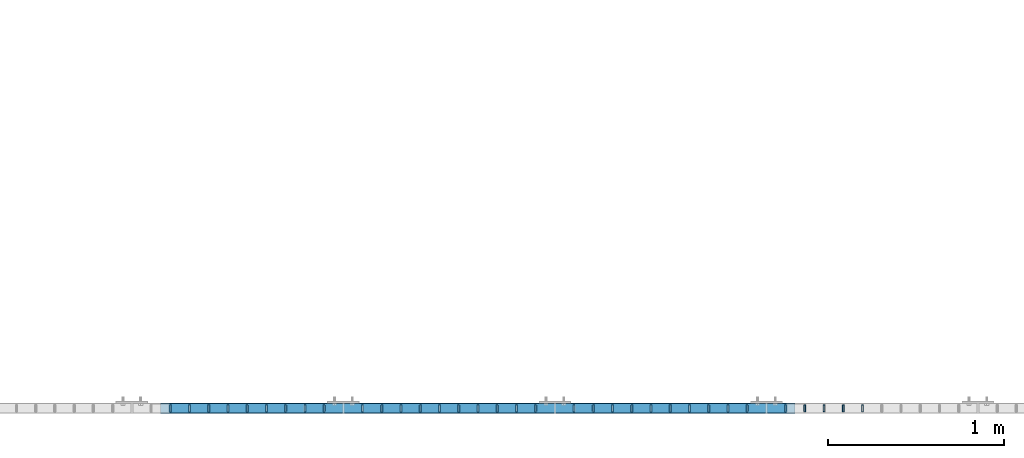
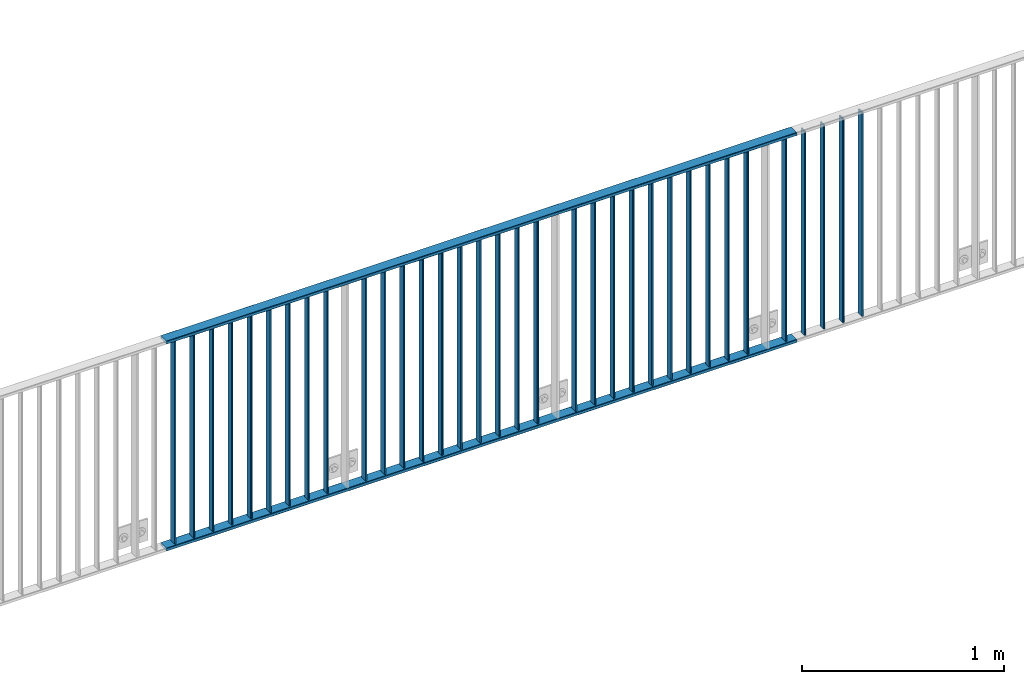
# One storey, part 30 of 156: 36 beams, 2 elements without a shape of their own.
"""IFC2X3 building model written with IfcOpenShell, lengths in millimetres."""

from ifc_helpers import new_model, si_unit, frame, origin_with_axes, origin_2d_with_axis, place, context, subcontext, project, spatial, hollow_rectangle, extrude, clip, halfspace, material, type_object, element, aggregate, save


model = new_model("IFC2X3")

# Units and contexts
model_context = context("Model", 3, precision=1e-05, world=origin_with_axes())
body_context = subcontext(model_context, "Body", "Model", "MODEL_VIEW")
ifc_project = project(units=[si_unit("LENGTHUNIT", "METRE", prefix="MILLI"), si_unit("AREAUNIT", "SQUARE_METRE"), si_unit("VOLUMEUNIT", "CUBIC_METRE"), si_unit("MASSUNIT", "GRAM", prefix="KILO"), si_unit("TIMEUNIT", "SECOND"), si_unit("PLANEANGLEUNIT", "RADIAN"), si_unit("SOLIDANGLEUNIT", "STERADIAN"), si_unit("THERMODYNAMICTEMPERATUREUNIT", "DEGREE_CELSIUS"), si_unit("LUMINOUSINTENSITYUNIT", "LUMEN")], contexts=[model_context])

# Site, building, storey
site_placement = place(None, origin_with_axes())
site = spatial("IfcSite", under=ifc_project, at=site_placement, CompositionType="ELEMENT")
building_placement = place(site_placement, origin_with_axes())
building = spatial("IfcBuilding", under=site, at=building_placement, Name="Undefined", CompositionType="ELEMENT")
storey_placement = place(building_placement, origin_with_axes())
storey = spatial("IfcBuildingStorey", under=building, at=storey_placement, Name="Undefined", CompositionType="ELEMENT", Elevation=0.0)

# Assembly, beams
assembly_1_placement = place(storey_placement, origin_with_axes())
assembly_1 = element("IfcElementAssembly", 1, at=assembly_1_placement, inside=storey, AssemblyPlace="NOTDEFINED", PredefinedType="RIGID_FRAME")
ifc_material = material(Name="STEEL/S235JR")
beam_type_1 = type_object("IfcBeamType", Name="K60/20/2", PredefinedType="NOTDEFINED")
beam_1_placement = place(assembly_1_placement, frame((43163.039999999, 8480.00209045411, 2740.0), z_axis=(0.0, 1.0, 0.0), x_axis=(1.0, 0.0, 0.0)))
beam_1 = element("IfcBeam", 2, at=beam_1_placement, type_object=beam_type_1, material=ifc_material, ObjectType="K60/20/2", context=body_context, shape_type="SweptSolid", body=[
    extrude(hollow_rectangle(XDim=20.0, YDim=60.0, WallThickness=2.0, InnerFilletRadius=2.0, OuterFilletRadius=4.0, at=origin_2d_with_axis()), frame((3600.0, 0.0, 0.0), z_axis=(-1.0, 0.0, 0.0), x_axis=(0.0, -1.0, 0.0)), (0.0, 0.0, 1.0), 3600.0),
])
beam_2_placement = place(assembly_1_placement, frame((43163.0400000136, 8479.98209040439, 3990.0), z_axis=(0.0, 1.0, 0.0), x_axis=(1.0, 0.0, 0.0)))
beam_2 = element("IfcBeam", 3, at=beam_2_placement, type_object=beam_type_1, material=ifc_material, ObjectType="K60/20/2", context=body_context, shape_type="SweptSolid", body=[
    extrude(hollow_rectangle(XDim=20.0, YDim=60.0, WallThickness=2.0, InnerFilletRadius=2.0, OuterFilletRadius=4.0, at=origin_2d_with_axis()), frame((3600.0, 0.0, 0.0), z_axis=(-1.0, 0.0, 0.0), x_axis=(0.0, -1.0, 0.0)), (0.0, 0.0, 1.0), 3600.0),
])

assembly_2_placement = place(storey_placement, origin_with_axes())
assembly_2 = element("IfcElementAssembly", 4, at=assembly_2_placement, inside=storey, AssemblyPlace="NOTDEFINED", PredefinedType="RIGID_FRAME")
beam_type_2 = type_object("IfcBeamType", Name="K40/10/1.5", PredefinedType="NOTDEFINED")
beam_3_placement = place(assembly_2_placement, frame((47145.449999999, 8480.00209765299, 3980.00000000003), z_axis=(0.0, 1.0, 0.0), x_axis=(0.0, 0.0, -1.0)))
beam_3 = element("IfcBeam", 5, at=beam_3_placement, type_object=beam_type_2, material=ifc_material, ObjectType="K40/10/1.5", context=body_context, shape_type="Clipping", body=[
    clip(extrude(hollow_rectangle(XDim=10.0, YDim=40.0, WallThickness=1.5, InnerFilletRadius=1.5, OuterFilletRadius=3.0, at=origin_2d_with_axis()), frame((1230.0, 0.0, 0.0), z_axis=(-1.0, 0.0, 0.0), x_axis=(0.0, -1.0, 0.0)), (0.0, 0.0, 1.0), 1230.0), halfspace(frame((-6.99999999997453, -4.34248751950508, 47.3810900558092), z_axis=(-1.0, 0.0, 0.0), x_axis=(0.0, 0.7683548141934, -0.640024124159258)), False)),
])
beam_4_placement = place(assembly_2_placement, frame((47036.359999999, 8480.00209765299, 3980.00000000003), z_axis=(0.0, 1.0, 0.0), x_axis=(0.0, 0.0, -1.0)))
beam_4 = element("IfcBeam", 6, at=beam_4_placement, type_object=beam_type_2, material=ifc_material, ObjectType="K40/10/1.5", context=body_context, shape_type="Clipping", body=[
    clip(extrude(hollow_rectangle(XDim=10.0, YDim=40.0, WallThickness=1.5, InnerFilletRadius=1.5, OuterFilletRadius=3.0, at=origin_2d_with_axis()), frame((1230.0, 0.0, 0.0), z_axis=(-1.0, 0.0, 0.0), x_axis=(0.0, -1.0, 0.0)), (0.0, 0.0, 1.0), 1230.0), halfspace(frame((-6.99999999997453, -4.34248751950508, 47.3810900558092), z_axis=(-1.0, 0.0, 0.0), x_axis=(0.0, 0.7683548141934, -0.640024124159258)), False)),
])
beam_5_placement = place(assembly_2_placement, frame((46927.269999999, 8480.00209765299, 3980.00000000003), z_axis=(0.0, 1.0, 0.0), x_axis=(0.0, 0.0, -1.0)))
beam_5 = element("IfcBeam", 7, at=beam_5_placement, type_object=beam_type_2, material=ifc_material, ObjectType="K40/10/1.5", context=body_context, shape_type="Clipping", body=[
    clip(extrude(hollow_rectangle(XDim=10.0, YDim=40.0, WallThickness=1.5, InnerFilletRadius=1.5, OuterFilletRadius=3.0, at=origin_2d_with_axis()), frame((1230.0, 0.0, 0.0), z_axis=(-1.0, 0.0, 0.0), x_axis=(0.0, -1.0, 0.0)), (0.0, 0.0, 1.0), 1230.0), halfspace(frame((-6.99999999997453, -4.34248751950508, 47.3810900558092), z_axis=(-1.0, 0.0, 0.0), x_axis=(0.0, 0.7683548141934, -0.640024124159258)), False)),
])
beam_6_placement = place(assembly_2_placement, frame((46818.179999999, 8480.00209765299, 3980.00000000003), z_axis=(0.0, 1.0, 0.0), x_axis=(0.0, 0.0, -1.0)))
beam_6 = element("IfcBeam", 8, at=beam_6_placement, type_object=beam_type_2, material=ifc_material, ObjectType="K40/10/1.5", context=body_context, shape_type="Clipping", body=[
    clip(extrude(hollow_rectangle(XDim=10.0, YDim=40.0, WallThickness=1.5, InnerFilletRadius=1.5, OuterFilletRadius=3.0, at=origin_2d_with_axis()), frame((1230.0, 0.0, 0.0), z_axis=(-1.0, 0.0, 0.0), x_axis=(0.0, -1.0, 0.0)), (0.0, 0.0, 1.0), 1230.0), halfspace(frame((-6.99999999997453, -4.34248751950508, 47.3810900558092), z_axis=(-1.0, 0.0, 0.0), x_axis=(0.0, 0.7683548141934, -0.640024124159258)), False)),
])
aggregate(assembly_2, [beam_3, beam_4, beam_5, beam_6])

# Beam
beam_7_placement = place(assembly_1_placement, frame((46709.089999999, 8480.00209765299, 3980.00000000003), z_axis=(0.0, 1.0, 0.0), x_axis=(0.0, 0.0, -1.0)))
beam_7 = element("IfcBeam", 9, at=beam_7_placement, type_object=beam_type_2, material=ifc_material, ObjectType="K40/10/1.5", context=body_context, shape_type="Clipping", body=[
    clip(clip(extrude(hollow_rectangle(XDim=10.0, YDim=40.0, WallThickness=1.5, InnerFilletRadius=1.5, OuterFilletRadius=3.0, at=origin_2d_with_axis()), frame((1230.0, 0.0, 0.0), z_axis=(-1.0, 0.0, 0.0), x_axis=(0.0, -1.0, 0.0)), (0.0, 0.0, 1.0), 1237.0), halfspace(frame((1237.00000000003, 4.34248751949781, 47.3810900558092), z_axis=(1.0, 0.0, 0.0), x_axis=(0.0, -0.768354814194188, -0.640024124158313)), False)), halfspace(frame((-6.99999999997408, 56.3749450528248, -3.21677038838243), z_axis=(-1.0, 0.0, 0.0), x_axis=(0.0, 0.0578016019523036, -0.998328089763955)), False)),
])

beam_8_placement = place(assembly_1_placement, frame((46490.899999999, 8480.00209765299, 3980.00000000003), z_axis=(0.0, 1.0, 0.0), x_axis=(0.0, 0.0, -1.0)))
beam_8 = element("IfcBeam", 10, at=beam_8_placement, type_object=beam_type_2, material=ifc_material, ObjectType="K40/10/1.5", context=body_context, shape_type="Clipping", body=[
    clip(extrude(hollow_rectangle(XDim=10.0, YDim=40.0, WallThickness=1.5, InnerFilletRadius=1.5, OuterFilletRadius=3.0, at=origin_2d_with_axis()), frame((1230.0, 0.0, 0.0), z_axis=(-1.0, 0.0, 0.0), x_axis=(0.0, -1.0, 0.0)), (0.0, 0.0, 1.0), 1230.0), halfspace(frame((-6.99999999997453, -4.34248751950508, 47.3810900558092), z_axis=(-1.0, 0.0, 0.0), x_axis=(0.0, 0.7683548141934, -0.640024124159258)), False)),
])

beam_9_placement = place(assembly_1_placement, frame((46381.809999999, 8480.00209765299, 3980.00000000003), z_axis=(0.0, 1.0, 0.0), x_axis=(0.0, 0.0, -1.0)))
beam_9 = element("IfcBeam", 11, at=beam_9_placement, type_object=beam_type_2, material=ifc_material, ObjectType="K40/10/1.5", context=body_context, shape_type="Clipping", body=[
    clip(extrude(hollow_rectangle(XDim=10.0, YDim=40.0, WallThickness=1.5, InnerFilletRadius=1.5, OuterFilletRadius=3.0, at=origin_2d_with_axis()), frame((1230.0, 0.0, 0.0), z_axis=(-1.0, 0.0, 0.0), x_axis=(0.0, -1.0, 0.0)), (0.0, 0.0, 1.0), 1230.0), halfspace(frame((-6.99999999997453, -4.34248751950508, 47.3810900558092), z_axis=(-1.0, 0.0, 0.0), x_axis=(0.0, 0.7683548141934, -0.640024124159258)), False)),
])

beam_10_placement = place(assembly_1_placement, frame((46272.719999999, 8480.00209765299, 3980.00000000003), z_axis=(0.0, 1.0, 0.0), x_axis=(0.0, 0.0, -1.0)))
beam_10 = element("IfcBeam", 12, at=beam_10_placement, type_object=beam_type_2, material=ifc_material, ObjectType="K40/10/1.5", context=body_context, shape_type="Clipping", body=[
    clip(extrude(hollow_rectangle(XDim=10.0, YDim=40.0, WallThickness=1.5, InnerFilletRadius=1.5, OuterFilletRadius=3.0, at=origin_2d_with_axis()), frame((1230.0, 0.0, 0.0), z_axis=(-1.0, 0.0, 0.0), x_axis=(0.0, -1.0, 0.0)), (0.0, 0.0, 1.0), 1230.0), halfspace(frame((-6.99999999997453, -4.34248751950508, 47.3810900558092), z_axis=(-1.0, 0.0, 0.0), x_axis=(0.0, 0.7683548141934, -0.640024124159258)), False)),
])

beam_11_placement = place(assembly_1_placement, frame((46163.629999999, 8480.00209765299, 3980.00000000003), z_axis=(0.0, 1.0, 0.0), x_axis=(0.0, 0.0, -1.0)))
beam_11 = element("IfcBeam", 13, at=beam_11_placement, type_object=beam_type_2, material=ifc_material, ObjectType="K40/10/1.5", context=body_context, shape_type="Clipping", body=[
    clip(extrude(hollow_rectangle(XDim=10.0, YDim=40.0, WallThickness=1.5, InnerFilletRadius=1.5, OuterFilletRadius=3.0, at=origin_2d_with_axis()), frame((1230.0, 0.0, 0.0), z_axis=(-1.0, 0.0, 0.0), x_axis=(0.0, -1.0, 0.0)), (0.0, 0.0, 1.0), 1230.0), halfspace(frame((-6.99999999997453, -4.34248751950508, 47.3810900558092), z_axis=(-1.0, 0.0, 0.0), x_axis=(0.0, 0.7683548141934, -0.640024124159258)), False)),
])

beam_12_placement = place(assembly_1_placement, frame((46054.539999999, 8480.00209765299, 3980.00000000003), z_axis=(0.0, 1.0, 0.0), x_axis=(0.0, 0.0, -1.0)))
beam_12 = element("IfcBeam", 14, at=beam_12_placement, type_object=beam_type_2, material=ifc_material, ObjectType="K40/10/1.5", context=body_context, shape_type="Clipping", body=[
    clip(extrude(hollow_rectangle(XDim=10.0, YDim=40.0, WallThickness=1.5, InnerFilletRadius=1.5, OuterFilletRadius=3.0, at=origin_2d_with_axis()), frame((1230.0, 0.0, 0.0), z_axis=(-1.0, 0.0, 0.0), x_axis=(0.0, -1.0, 0.0)), (0.0, 0.0, 1.0), 1230.0), halfspace(frame((-6.99999999997453, -4.34248751950508, 47.3810900558092), z_axis=(-1.0, 0.0, 0.0), x_axis=(0.0, 0.7683548141934, -0.640024124159258)), False)),
])

beam_13_placement = place(assembly_1_placement, frame((45945.449999999, 8480.00209765299, 3980.00000000003), z_axis=(0.0, 1.0, 0.0), x_axis=(0.0, 0.0, -1.0)))
beam_13 = element("IfcBeam", 15, at=beam_13_placement, type_object=beam_type_2, material=ifc_material, ObjectType="K40/10/1.5", context=body_context, shape_type="Clipping", body=[
    clip(extrude(hollow_rectangle(XDim=10.0, YDim=40.0, WallThickness=1.5, InnerFilletRadius=1.5, OuterFilletRadius=3.0, at=origin_2d_with_axis()), frame((1230.0, 0.0, 0.0), z_axis=(-1.0, 0.0, 0.0), x_axis=(0.0, -1.0, 0.0)), (0.0, 0.0, 1.0), 1230.0), halfspace(frame((-6.99999999997453, -4.34248751950508, 47.3810900558092), z_axis=(-1.0, 0.0, 0.0), x_axis=(0.0, 0.7683548141934, -0.640024124159258)), False)),
])

beam_14_placement = place(assembly_1_placement, frame((45836.359999999, 8480.00209765299, 3980.00000000003), z_axis=(0.0, 1.0, 0.0), x_axis=(0.0, 0.0, -1.0)))
beam_14 = element("IfcBeam", 16, at=beam_14_placement, type_object=beam_type_2, material=ifc_material, ObjectType="K40/10/1.5", context=body_context, shape_type="Clipping", body=[
    clip(extrude(hollow_rectangle(XDim=10.0, YDim=40.0, WallThickness=1.5, InnerFilletRadius=1.5, OuterFilletRadius=3.0, at=origin_2d_with_axis()), frame((1230.0, 0.0, 0.0), z_axis=(-1.0, 0.0, 0.0), x_axis=(0.0, -1.0, 0.0)), (0.0, 0.0, 1.0), 1230.0), halfspace(frame((-6.99999999997453, -4.34248751950508, 47.3810900558092), z_axis=(-1.0, 0.0, 0.0), x_axis=(0.0, 0.7683548141934, -0.640024124159258)), False)),
])

beam_15_placement = place(assembly_1_placement, frame((45727.269999999, 8480.00209765299, 3980.00000000003), z_axis=(0.0, 1.0, 0.0), x_axis=(0.0, 0.0, -1.0)))
beam_15 = element("IfcBeam", 17, at=beam_15_placement, type_object=beam_type_2, material=ifc_material, ObjectType="K40/10/1.5", context=body_context, shape_type="Clipping", body=[
    clip(extrude(hollow_rectangle(XDim=10.0, YDim=40.0, WallThickness=1.5, InnerFilletRadius=1.5, OuterFilletRadius=3.0, at=origin_2d_with_axis()), frame((1230.0, 0.0, 0.0), z_axis=(-1.0, 0.0, 0.0), x_axis=(0.0, -1.0, 0.0)), (0.0, 0.0, 1.0), 1230.0), halfspace(frame((-6.99999999997453, -4.34248751950508, 47.3810900558092), z_axis=(-1.0, 0.0, 0.0), x_axis=(0.0, 0.7683548141934, -0.640024124159258)), False)),
])

beam_16_placement = place(assembly_1_placement, frame((45618.179999999, 8480.00209765299, 3980.00000000003), z_axis=(0.0, 1.0, 0.0), x_axis=(0.0, 0.0, -1.0)))
beam_16 = element("IfcBeam", 18, at=beam_16_placement, type_object=beam_type_2, material=ifc_material, ObjectType="K40/10/1.5", context=body_context, shape_type="Clipping", body=[
    clip(extrude(hollow_rectangle(XDim=10.0, YDim=40.0, WallThickness=1.5, InnerFilletRadius=1.5, OuterFilletRadius=3.0, at=origin_2d_with_axis()), frame((1230.0, 0.0, 0.0), z_axis=(-1.0, 0.0, 0.0), x_axis=(0.0, -1.0, 0.0)), (0.0, 0.0, 1.0), 1230.0), halfspace(frame((-6.99999999997453, -4.34248751950508, 47.3810900558092), z_axis=(-1.0, 0.0, 0.0), x_axis=(0.0, 0.7683548141934, -0.640024124159258)), False)),
])

beam_17_placement = place(assembly_1_placement, frame((45509.089999999, 8480.00209765299, 3980.00000000003), z_axis=(0.0, 1.0, 0.0), x_axis=(0.0, 0.0, -1.0)))
beam_17 = element("IfcBeam", 19, at=beam_17_placement, type_object=beam_type_2, material=ifc_material, ObjectType="K40/10/1.5", context=body_context, shape_type="Clipping", body=[
    clip(extrude(hollow_rectangle(XDim=10.0, YDim=40.0, WallThickness=1.5, InnerFilletRadius=1.5, OuterFilletRadius=3.0, at=origin_2d_with_axis()), frame((1230.0, 0.0, 0.0), z_axis=(-1.0, 0.0, 0.0), x_axis=(0.0, -1.0, 0.0)), (0.0, 0.0, 1.0), 1230.0), halfspace(frame((-6.99999999997453, -4.34248751950508, 47.3810900558092), z_axis=(-1.0, 0.0, 0.0), x_axis=(0.0, 0.7683548141934, -0.640024124159258)), False)),
])

beam_18_placement = place(assembly_1_placement, frame((45290.899999999, 8480.00209765299, 3980.00000000003), z_axis=(0.0, 1.0, 0.0), x_axis=(0.0, 0.0, -1.0)))
beam_18 = element("IfcBeam", 20, at=beam_18_placement, type_object=beam_type_2, material=ifc_material, ObjectType="K40/10/1.5", context=body_context, shape_type="Clipping", body=[
    clip(extrude(hollow_rectangle(XDim=10.0, YDim=40.0, WallThickness=1.5, InnerFilletRadius=1.5, OuterFilletRadius=3.0, at=origin_2d_with_axis()), frame((1230.0, 0.0, 0.0), z_axis=(-1.0, 0.0, 0.0), x_axis=(0.0, -1.0, 0.0)), (0.0, 0.0, 1.0), 1230.0), halfspace(frame((-6.99999999997453, -4.34248751950508, 47.3810900558092), z_axis=(-1.0, 0.0, 0.0), x_axis=(0.0, 0.7683548141934, -0.640024124159258)), False)),
])

beam_19_placement = place(assembly_1_placement, frame((45181.809999999, 8480.00209765299, 3980.00000000003), z_axis=(0.0, 1.0, 0.0), x_axis=(0.0, 0.0, -1.0)))
beam_19 = element("IfcBeam", 21, at=beam_19_placement, type_object=beam_type_2, material=ifc_material, ObjectType="K40/10/1.5", context=body_context, shape_type="Clipping", body=[
    clip(extrude(hollow_rectangle(XDim=10.0, YDim=40.0, WallThickness=1.5, InnerFilletRadius=1.5, OuterFilletRadius=3.0, at=origin_2d_with_axis()), frame((1230.0, 0.0, 0.0), z_axis=(-1.0, 0.0, 0.0), x_axis=(0.0, -1.0, 0.0)), (0.0, 0.0, 1.0), 1230.0), halfspace(frame((-6.99999999997453, -4.34248751950508, 47.3810900558092), z_axis=(-1.0, 0.0, 0.0), x_axis=(0.0, 0.7683548141934, -0.640024124159258)), False)),
])

beam_20_placement = place(assembly_1_placement, frame((45072.719999999, 8480.00209765299, 3980.00000000003), z_axis=(0.0, 1.0, 0.0), x_axis=(0.0, 0.0, -1.0)))
beam_20 = element("IfcBeam", 22, at=beam_20_placement, type_object=beam_type_2, material=ifc_material, ObjectType="K40/10/1.5", context=body_context, shape_type="Clipping", body=[
    clip(extrude(hollow_rectangle(XDim=10.0, YDim=40.0, WallThickness=1.5, InnerFilletRadius=1.5, OuterFilletRadius=3.0, at=origin_2d_with_axis()), frame((1230.0, 0.0, 0.0), z_axis=(-1.0, 0.0, 0.0), x_axis=(0.0, -1.0, 0.0)), (0.0, 0.0, 1.0), 1230.0), halfspace(frame((-6.99999999997453, -4.34248751950508, 47.3810900558092), z_axis=(-1.0, 0.0, 0.0), x_axis=(0.0, 0.7683548141934, -0.640024124159258)), False)),
])

beam_21_placement = place(assembly_1_placement, frame((44963.629999999, 8480.00209765299, 3980.00000000003), z_axis=(0.0, 1.0, 0.0), x_axis=(0.0, 0.0, -1.0)))
beam_21 = element("IfcBeam", 23, at=beam_21_placement, type_object=beam_type_2, material=ifc_material, ObjectType="K40/10/1.5", context=body_context, shape_type="Clipping", body=[
    clip(extrude(hollow_rectangle(XDim=10.0, YDim=40.0, WallThickness=1.5, InnerFilletRadius=1.5, OuterFilletRadius=3.0, at=origin_2d_with_axis()), frame((1230.0, 0.0, 0.0), z_axis=(-1.0, 0.0, 0.0), x_axis=(0.0, -1.0, 0.0)), (0.0, 0.0, 1.0), 1230.0), halfspace(frame((-6.99999999997453, -4.34248751950508, 47.3810900558092), z_axis=(-1.0, 0.0, 0.0), x_axis=(0.0, 0.7683548141934, -0.640024124159258)), False)),
])

beam_22_placement = place(assembly_1_placement, frame((44854.539999999, 8480.00209765299, 3980.00000000003), z_axis=(0.0, 1.0, 0.0), x_axis=(0.0, 0.0, -1.0)))
beam_22 = element("IfcBeam", 24, at=beam_22_placement, type_object=beam_type_2, material=ifc_material, ObjectType="K40/10/1.5", context=body_context, shape_type="Clipping", body=[
    clip(extrude(hollow_rectangle(XDim=10.0, YDim=40.0, WallThickness=1.5, InnerFilletRadius=1.5, OuterFilletRadius=3.0, at=origin_2d_with_axis()), frame((1230.0, 0.0, 0.0), z_axis=(-1.0, 0.0, 0.0), x_axis=(0.0, -1.0, 0.0)), (0.0, 0.0, 1.0), 1230.0), halfspace(frame((-6.99999999997453, -4.34248751950508, 47.3810900558092), z_axis=(-1.0, 0.0, 0.0), x_axis=(0.0, 0.7683548141934, -0.640024124159258)), False)),
])

beam_23_placement = place(assembly_1_placement, frame((44745.449999999, 8480.00209765299, 3980.00000000003), z_axis=(0.0, 1.0, 0.0), x_axis=(0.0, 0.0, -1.0)))
beam_23 = element("IfcBeam", 25, at=beam_23_placement, type_object=beam_type_2, material=ifc_material, ObjectType="K40/10/1.5", context=body_context, shape_type="Clipping", body=[
    clip(extrude(hollow_rectangle(XDim=10.0, YDim=40.0, WallThickness=1.5, InnerFilletRadius=1.5, OuterFilletRadius=3.0, at=origin_2d_with_axis()), frame((1230.0, 0.0, 0.0), z_axis=(-1.0, 0.0, 0.0), x_axis=(0.0, -1.0, 0.0)), (0.0, 0.0, 1.0), 1230.0), halfspace(frame((-6.99999999997453, -4.34248751950508, 47.3810900558092), z_axis=(-1.0, 0.0, 0.0), x_axis=(0.0, 0.7683548141934, -0.640024124159258)), False)),
])

beam_24_placement = place(assembly_1_placement, frame((44636.359999999, 8480.00209765299, 3980.00000000003), z_axis=(0.0, 1.0, 0.0), x_axis=(0.0, 0.0, -1.0)))
beam_24 = element("IfcBeam", 26, at=beam_24_placement, type_object=beam_type_2, material=ifc_material, ObjectType="K40/10/1.5", context=body_context, shape_type="Clipping", body=[
    clip(extrude(hollow_rectangle(XDim=10.0, YDim=40.0, WallThickness=1.5, InnerFilletRadius=1.5, OuterFilletRadius=3.0, at=origin_2d_with_axis()), frame((1230.0, 0.0, 0.0), z_axis=(-1.0, 0.0, 0.0), x_axis=(0.0, -1.0, 0.0)), (0.0, 0.0, 1.0), 1230.0), halfspace(frame((-6.99999999997453, -4.34248751950508, 47.3810900558092), z_axis=(-1.0, 0.0, 0.0), x_axis=(0.0, 0.7683548141934, -0.640024124159258)), False)),
])

beam_25_placement = place(assembly_1_placement, frame((44527.269999999, 8480.00209765299, 3980.00000000003), z_axis=(0.0, 1.0, 0.0), x_axis=(0.0, 0.0, -1.0)))
beam_25 = element("IfcBeam", 27, at=beam_25_placement, type_object=beam_type_2, material=ifc_material, ObjectType="K40/10/1.5", context=body_context, shape_type="Clipping", body=[
    clip(extrude(hollow_rectangle(XDim=10.0, YDim=40.0, WallThickness=1.5, InnerFilletRadius=1.5, OuterFilletRadius=3.0, at=origin_2d_with_axis()), frame((1230.0, 0.0, 0.0), z_axis=(-1.0, 0.0, 0.0), x_axis=(0.0, -1.0, 0.0)), (0.0, 0.0, 1.0), 1230.0), halfspace(frame((-6.99999999997453, -4.34248751950508, 47.3810900558092), z_axis=(-1.0, 0.0, 0.0), x_axis=(0.0, 0.7683548141934, -0.640024124159258)), False)),
])

beam_26_placement = place(assembly_1_placement, frame((44418.179999999, 8480.00209765299, 3980.00000000003), z_axis=(0.0, 1.0, 0.0), x_axis=(0.0, 0.0, -1.0)))
beam_26 = element("IfcBeam", 28, at=beam_26_placement, type_object=beam_type_2, material=ifc_material, ObjectType="K40/10/1.5", context=body_context, shape_type="Clipping", body=[
    clip(extrude(hollow_rectangle(XDim=10.0, YDim=40.0, WallThickness=1.5, InnerFilletRadius=1.5, OuterFilletRadius=3.0, at=origin_2d_with_axis()), frame((1230.0, 0.0, 0.0), z_axis=(-1.0, 0.0, 0.0), x_axis=(0.0, -1.0, 0.0)), (0.0, 0.0, 1.0), 1230.0), halfspace(frame((-6.99999999997453, -4.34248751950508, 47.3810900558092), z_axis=(-1.0, 0.0, 0.0), x_axis=(0.0, 0.7683548141934, -0.640024124159258)), False)),
])

beam_27_placement = place(assembly_1_placement, frame((44309.089999999, 8480.00209765299, 3980.00000000003), z_axis=(0.0, 1.0, 0.0), x_axis=(0.0, 0.0, -1.0)))
beam_27 = element("IfcBeam", 29, at=beam_27_placement, type_object=beam_type_2, material=ifc_material, ObjectType="K40/10/1.5", context=body_context, shape_type="Clipping", body=[
    clip(extrude(hollow_rectangle(XDim=10.0, YDim=40.0, WallThickness=1.5, InnerFilletRadius=1.5, OuterFilletRadius=3.0, at=origin_2d_with_axis()), frame((1230.0, 0.0, 0.0), z_axis=(-1.0, 0.0, 0.0), x_axis=(0.0, -1.0, 0.0)), (0.0, 0.0, 1.0), 1230.0), halfspace(frame((-6.99999999997453, -4.34248751950508, 47.3810900558092), z_axis=(-1.0, 0.0, 0.0), x_axis=(0.0, 0.7683548141934, -0.640024124159258)), False)),
])

beam_28_placement = place(assembly_1_placement, frame((44090.899999999, 8480.00209765299, 3980.00000000003), z_axis=(0.0, 1.0, 0.0), x_axis=(0.0, 0.0, -1.0)))
beam_28 = element("IfcBeam", 30, at=beam_28_placement, type_object=beam_type_2, material=ifc_material, ObjectType="K40/10/1.5", context=body_context, shape_type="Clipping", body=[
    clip(extrude(hollow_rectangle(XDim=10.0, YDim=40.0, WallThickness=1.5, InnerFilletRadius=1.5, OuterFilletRadius=3.0, at=origin_2d_with_axis()), frame((1230.0, 0.0, 0.0), z_axis=(-1.0, 0.0, 0.0), x_axis=(0.0, -1.0, 0.0)), (0.0, 0.0, 1.0), 1230.0), halfspace(frame((-6.99999999997453, -4.34248751950508, 47.3810900558092), z_axis=(-1.0, 0.0, 0.0), x_axis=(0.0, 0.7683548141934, -0.640024124159258)), False)),
])

beam_29_placement = place(assembly_1_placement, frame((43981.809999999, 8480.00209765299, 3980.00000000003), z_axis=(0.0, 1.0, 0.0), x_axis=(0.0, 0.0, -1.0)))
beam_29 = element("IfcBeam", 31, at=beam_29_placement, type_object=beam_type_2, material=ifc_material, ObjectType="K40/10/1.5", context=body_context, shape_type="Clipping", body=[
    clip(extrude(hollow_rectangle(XDim=10.0, YDim=40.0, WallThickness=1.5, InnerFilletRadius=1.5, OuterFilletRadius=3.0, at=origin_2d_with_axis()), frame((1230.0, 0.0, 0.0), z_axis=(-1.0, 0.0, 0.0), x_axis=(0.0, -1.0, 0.0)), (0.0, 0.0, 1.0), 1230.0), halfspace(frame((-6.99999999997453, -4.34248751950508, 47.3810900558092), z_axis=(-1.0, 0.0, 0.0), x_axis=(0.0, 0.7683548141934, -0.640024124159258)), False)),
])

beam_30_placement = place(assembly_1_placement, frame((43872.719999999, 8480.00209765299, 3980.00000000003), z_axis=(0.0, 1.0, 0.0), x_axis=(0.0, 0.0, -1.0)))
beam_30 = element("IfcBeam", 32, at=beam_30_placement, type_object=beam_type_2, material=ifc_material, ObjectType="K40/10/1.5", context=body_context, shape_type="Clipping", body=[
    clip(extrude(hollow_rectangle(XDim=10.0, YDim=40.0, WallThickness=1.5, InnerFilletRadius=1.5, OuterFilletRadius=3.0, at=origin_2d_with_axis()), frame((1230.0, 0.0, 0.0), z_axis=(-1.0, 0.0, 0.0), x_axis=(0.0, -1.0, 0.0)), (0.0, 0.0, 1.0), 1230.0), halfspace(frame((-6.99999999997453, -4.34248751950508, 47.3810900558092), z_axis=(-1.0, 0.0, 0.0), x_axis=(0.0, 0.7683548141934, -0.640024124159258)), False)),
])

beam_31_placement = place(assembly_1_placement, frame((43763.629999999, 8480.00209765299, 3980.00000000003), z_axis=(0.0, 1.0, 0.0), x_axis=(0.0, 0.0, -1.0)))
beam_31 = element("IfcBeam", 33, at=beam_31_placement, type_object=beam_type_2, material=ifc_material, ObjectType="K40/10/1.5", context=body_context, shape_type="Clipping", body=[
    clip(extrude(hollow_rectangle(XDim=10.0, YDim=40.0, WallThickness=1.5, InnerFilletRadius=1.5, OuterFilletRadius=3.0, at=origin_2d_with_axis()), frame((1230.0, 0.0, 0.0), z_axis=(-1.0, 0.0, 0.0), x_axis=(0.0, -1.0, 0.0)), (0.0, 0.0, 1.0), 1230.0), halfspace(frame((-6.99999999997453, -4.34248751950508, 47.3810900558092), z_axis=(-1.0, 0.0, 0.0), x_axis=(0.0, 0.7683548141934, -0.640024124159258)), False)),
])

beam_32_placement = place(assembly_1_placement, frame((43654.539999999, 8480.00209765299, 3980.00000000003), z_axis=(0.0, 1.0, 0.0), x_axis=(0.0, 0.0, -1.0)))
beam_32 = element("IfcBeam", 34, at=beam_32_placement, type_object=beam_type_2, material=ifc_material, ObjectType="K40/10/1.5", context=body_context, shape_type="Clipping", body=[
    clip(extrude(hollow_rectangle(XDim=10.0, YDim=40.0, WallThickness=1.5, InnerFilletRadius=1.5, OuterFilletRadius=3.0, at=origin_2d_with_axis()), frame((1230.0, 0.0, 0.0), z_axis=(-1.0, 0.0, 0.0), x_axis=(0.0, -1.0, 0.0)), (0.0, 0.0, 1.0), 1230.0), halfspace(frame((-6.99999999997453, -4.34248751950508, 47.3810900558092), z_axis=(-1.0, 0.0, 0.0), x_axis=(0.0, 0.7683548141934, -0.640024124159258)), False)),
])

beam_33_placement = place(assembly_1_placement, frame((43545.449999999, 8480.00209765299, 3980.00000000003), z_axis=(0.0, 1.0, 0.0), x_axis=(0.0, 0.0, -1.0)))
beam_33 = element("IfcBeam", 35, at=beam_33_placement, type_object=beam_type_2, material=ifc_material, ObjectType="K40/10/1.5", context=body_context, shape_type="Clipping", body=[
    clip(extrude(hollow_rectangle(XDim=10.0, YDim=40.0, WallThickness=1.5, InnerFilletRadius=1.5, OuterFilletRadius=3.0, at=origin_2d_with_axis()), frame((1230.0, 0.0, 0.0), z_axis=(-1.0, 0.0, 0.0), x_axis=(0.0, -1.0, 0.0)), (0.0, 0.0, 1.0), 1230.0), halfspace(frame((-6.99999999997453, -4.34248751950508, 47.3810900558092), z_axis=(-1.0, 0.0, 0.0), x_axis=(0.0, 0.7683548141934, -0.640024124159258)), False)),
])

beam_34_placement = place(assembly_1_placement, frame((43436.359999999, 8480.00209765299, 3980.00000000003), z_axis=(0.0, 1.0, 0.0), x_axis=(0.0, 0.0, -1.0)))
beam_34 = element("IfcBeam", 36, at=beam_34_placement, type_object=beam_type_2, material=ifc_material, ObjectType="K40/10/1.5", context=body_context, shape_type="Clipping", body=[
    clip(extrude(hollow_rectangle(XDim=10.0, YDim=40.0, WallThickness=1.5, InnerFilletRadius=1.5, OuterFilletRadius=3.0, at=origin_2d_with_axis()), frame((1230.0, 0.0, 0.0), z_axis=(-1.0, 0.0, 0.0), x_axis=(0.0, -1.0, 0.0)), (0.0, 0.0, 1.0), 1230.0), halfspace(frame((-6.99999999997453, -4.34248751950508, 47.3810900558092), z_axis=(-1.0, 0.0, 0.0), x_axis=(0.0, 0.7683548141934, -0.640024124159258)), False)),
])

beam_35_placement = place(assembly_1_placement, frame((43327.269999999, 8480.00209765299, 3980.00000000003), z_axis=(0.0, 1.0, 0.0), x_axis=(0.0, 0.0, -1.0)))
beam_35 = element("IfcBeam", 37, at=beam_35_placement, type_object=beam_type_2, material=ifc_material, ObjectType="K40/10/1.5", context=body_context, shape_type="Clipping", body=[
    clip(extrude(hollow_rectangle(XDim=10.0, YDim=40.0, WallThickness=1.5, InnerFilletRadius=1.5, OuterFilletRadius=3.0, at=origin_2d_with_axis()), frame((1230.0, 0.0, 0.0), z_axis=(-1.0, 0.0, 0.0), x_axis=(0.0, -1.0, 0.0)), (0.0, 0.0, 1.0), 1230.0), halfspace(frame((-6.99999999997453, -4.34248751950508, 47.3810900558092), z_axis=(-1.0, 0.0, 0.0), x_axis=(0.0, 0.7683548141934, -0.640024124159258)), False)),
])

beam_36_placement = place(assembly_1_placement, frame((43218.179999999, 8480.00209765299, 3980.00000000003), z_axis=(0.0, 1.0, 0.0), x_axis=(0.0, 0.0, -1.0)))
beam_36 = element("IfcBeam", 38, at=beam_36_placement, type_object=beam_type_2, material=ifc_material, ObjectType="K40/10/1.5", context=body_context, shape_type="Clipping", body=[
    clip(extrude(hollow_rectangle(XDim=10.0, YDim=40.0, WallThickness=1.5, InnerFilletRadius=1.5, OuterFilletRadius=3.0, at=origin_2d_with_axis()), frame((1230.0, 0.0, 0.0), z_axis=(-1.0, 0.0, 0.0), x_axis=(0.0, -1.0, 0.0)), (0.0, 0.0, 1.0), 1230.0), halfspace(frame((-6.99999999997453, -4.34248751950508, 47.3810900558092), z_axis=(-1.0, 0.0, 0.0), x_axis=(0.0, 0.7683548141934, -0.640024124159258)), False)),
])

aggregate(assembly_1, [beam_1, beam_2, beam_7, beam_8, beam_9, beam_10, beam_11, beam_12, beam_13, beam_14, beam_15, beam_16, beam_17, beam_18, beam_19, beam_20, beam_21, beam_22, beam_23, beam_24, beam_25, beam_26, beam_27, beam_28, beam_29, beam_30, beam_31, beam_32, beam_33, beam_34, beam_35, beam_36])

save(model, "model.ifc")
